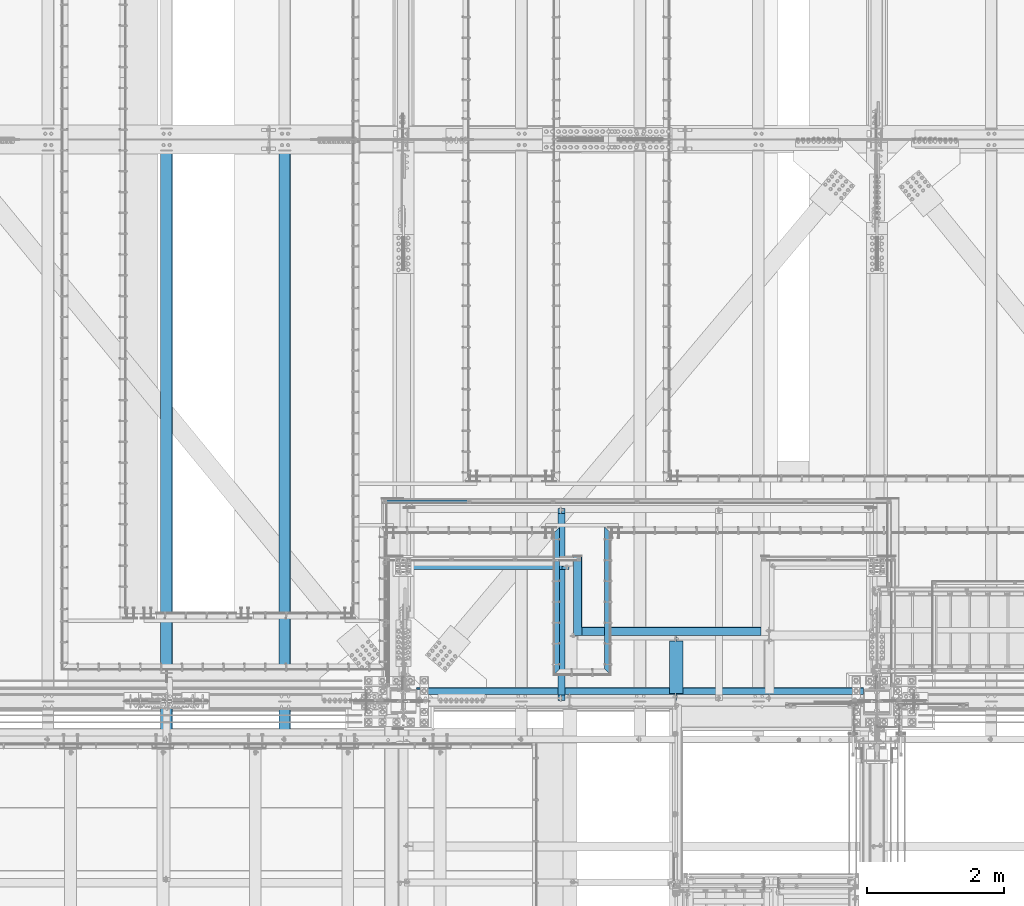
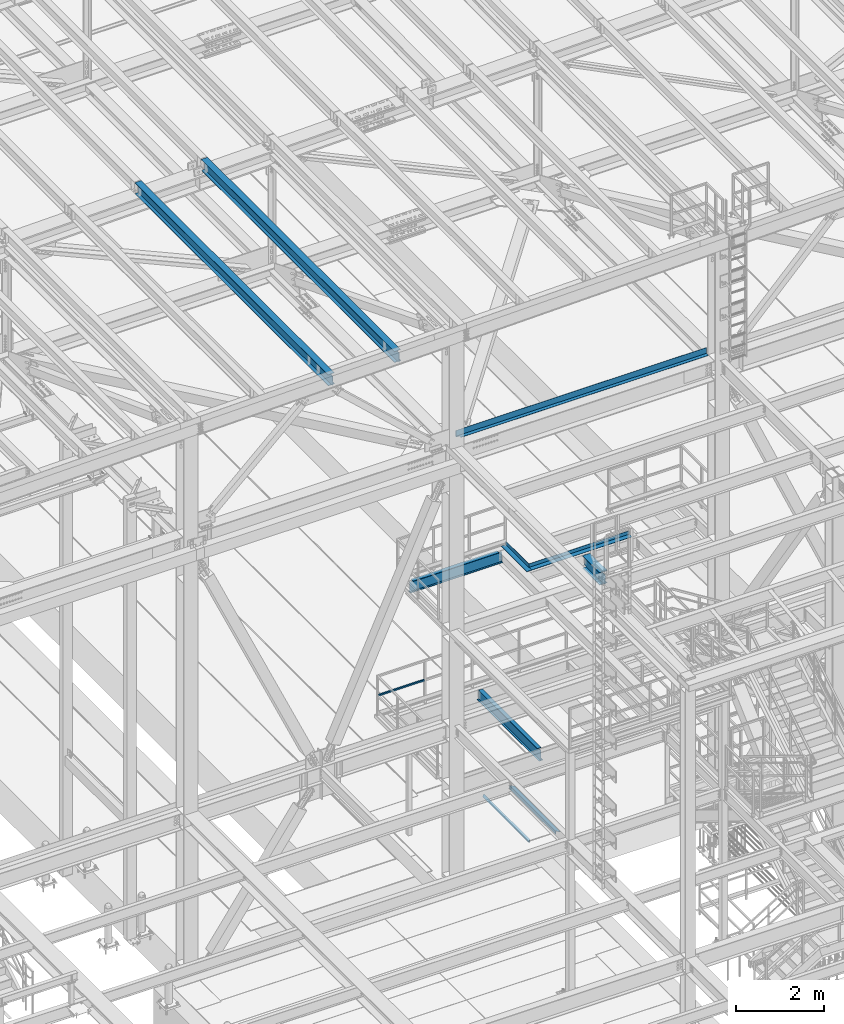
# One storey, part 1782 of 3843: 11 beams, 11 elements without a shape of their own.
"""IFC2X3 building model written with IfcOpenShell, lengths in millimetres."""

from ifc_helpers import new_model, si_unit, frame, origin_with_axes, place, context, subcontext, project, spatial, faceted_brep, material, type_object, element, aggregate, save


model = new_model("IFC2X3")

# Units and contexts
model_context = context("Model", 3, precision=1e-05, world=origin_with_axes())
body_context = subcontext(model_context, "Body", "Model", "MODEL_VIEW")
ifc_project = project(units=[si_unit("LENGTHUNIT", "METRE", prefix="MILLI"), si_unit("AREAUNIT", "SQUARE_METRE"), si_unit("VOLUMEUNIT", "CUBIC_METRE"), si_unit("MASSUNIT", "GRAM", prefix="KILO"), si_unit("TIMEUNIT", "SECOND"), si_unit("PLANEANGLEUNIT", "RADIAN"), si_unit("SOLIDANGLEUNIT", "STERADIAN"), si_unit("THERMODYNAMICTEMPERATUREUNIT", "DEGREE_CELSIUS"), si_unit("LUMINOUSINTENSITYUNIT", "LUMEN")], contexts=[model_context])

# Site, building, storey
site_placement = place(None, origin_with_axes())
site = spatial("IfcSite", under=ifc_project, at=site_placement, CompositionType="ELEMENT")
building_placement = place(site_placement, origin_with_axes())
building = spatial("IfcBuilding", under=site, at=building_placement, Name="Undefined", CompositionType="ELEMENT")
storey_placement = place(building_placement, origin_with_axes())
storey = spatial("IfcBuildingStorey", under=building, at=storey_placement, Name="Undefined", CompositionType="ELEMENT", Elevation=0.0)

# Assembly, beam
assembly_1_placement = place(storey_placement, origin_with_axes())
assembly_1 = element("IfcElementAssembly", 1, at=assembly_1_placement, inside=storey, Name="EMBED_ANGLE", AssemblyPlace="NOTDEFINED", PredefinedType="RIGID_FRAME")
ifc_material_1 = material(Name="STEEL/A36")
beam_type_1 = type_object("IfcBeamType", Name="L3-1/2X3-1/2X5/16", PredefinedType="NOTDEFINED")
beam_1_placement = place(assembly_1_placement, frame((51238.9119901352, 26000.0749968906, 30410.15), z_axis=(0.0, 0.0, -1.0), x_axis=(0.0, 1.0, 0.0)))
beam_1 = element("IfcBeam", 2, at=beam_1_placement, type_object=beam_type_1, material=ifc_material_1, Name="EMBED_ANGLE", ObjectType="L3-1/2X3-1/2X5/16", context=body_context, shape_type="Brep", body=[
    faceted_brep([(88.8999999971129, 44.4500000000007, -44.4499999999971), (88.8999999965163, 44.4499999999971, 44.4500000000007), (2168.52499994361, 44.4499999956824, 44.4500000000007), (2168.52499994361, 44.4499999956824, -44.4500000000007), (80.9624999965163, 36.5124999999971, 44.4500000000007), (2160.58750050484, 36.5124999957043, 44.4500000000007), (80.9624999971129, 36.5125000000007, -36.5124999999971), (2160.58750050484, 36.5124999957043, -36.5125000000007), (3.63797880709171e-12, -44.4499999999971, -36.5125000000007), (2079.62500622933, -44.4500000041371, -36.5125000000007), (3.63797880709171e-12, -44.4499999999971, -44.4500000000007), (2079.62500622933, -44.4500000041371, -44.4500000000007)], [[[0, 1, 2, 3]], [[1, 4, 5, 2]], [[4, 6, 7, 5]], [[6, 8, 9, 7]], [[8, 10, 11, 9]], [[10, 0, 3, 11]], [[5, 7, 9, 11, 3, 2]], [[10, 8, 6, 4, 1, 0]]]),
])
aggregate(assembly_1, [beam_1])

assembly_2_placement = place(storey_placement, origin_with_axes())
assembly_2 = element("IfcElementAssembly", 3, at=assembly_2_placement, inside=storey, Name="EMBED_ANGLE", AssemblyPlace="NOTDEFINED", PredefinedType="RIGID_FRAME")
beam_2_placement = place(assembly_2_placement, frame((51988.2120145524, 26000.0749965095, 30410.15), z_axis=(1.0, 0.0, 0.0), x_axis=(0.0, 1.0, 0.0)))
beam_2 = element("IfcBeam", 4, at=beam_2_placement, type_object=beam_type_1, material=ifc_material_1, Name="EMBED_ANGLE", ObjectType="L3-1/2X3-1/2X5/16", context=body_context, shape_type="Brep", body=[
    faceted_brep([(88.8999999971129, 44.4500000000007, -44.4499999999971), (-3.63797880709171e-12, 44.4499999999971, 44.4500000000007), (2079.62500364689, 44.4500000000007, 44.4500000037006), (2168.52499994361, 44.4499999956824, -44.4500000000007), (-3.63797880709171e-12, 36.5124999999971, 44.4500000000007), (2079.62500364689, 36.5125000000007, 44.4500000037006), (80.9624999971129, 36.5125000000007, -36.5124999999971), (2160.58750050484, 36.5124999957043, -36.5125000000007), (80.9624999971129, -44.4500000000007, -36.5124999999971), (2160.58750334254, -44.4500000000007, -36.5124999961554), (88.8999999971129, -44.4500000000007, -44.4499999999971), (2168.5250033127, -44.4500000000007, -44.4499999961481)], [[[0, 1, 2, 3]], [[1, 4, 5, 2]], [[4, 6, 7, 5]], [[6, 8, 9, 7]], [[8, 10, 11, 9]], [[10, 0, 3, 11]], [[5, 7, 9, 11, 3, 2]], [[10, 8, 6, 4, 1, 0]]]),
])
aggregate(assembly_2, [beam_2])

assembly_3_placement = place(storey_placement, origin_with_axes())
assembly_3 = element("IfcElementAssembly", 5, at=assembly_3_placement, inside=storey, Name="RAIL", AssemblyPlace="NOTDEFINED", PredefinedType="RIGID_FRAME")
ifc_material_2 = material()
beam_type_2 = type_object("IfcBeamType", Name="HSS1-1/2X1-1/2X1/4", PredefinedType="NOTDEFINED")
beam_3_placement = place(assembly_3_placement, frame((49954.3916666376, 28543.2499999997, 33832.8000002631), z_axis=(0.0, 0.0, 1.0), x_axis=(-1.0, 0.0, 0.0)))
beam_3 = element("IfcBeam", 6, at=beam_3_placement, type_object=beam_type_2, material=ifc_material_2, Name="RAIL", ObjectType="HSS1-1/2X1-1/2X1/4", context=body_context, shape_type="Brep", body=[
    faceted_brep([(1211.79166666124, -19.0499999996136, 19.0499992350015), (1211.79166666124, -19.0499992350015, -19.0499992350015), (1211.79166666124, 19.0499992350015, -19.0499992350015), (1211.79166666124, 19.0499992350015, 19.0499992350015), (1211.79166666124, -12.6999993300014, 12.6999993299978), (1211.79166666124, 12.6999993300014, 12.6999993299978), (1211.79166666124, 12.6999993300014, -12.6999993299978), (1211.79166666124, -12.6999993300014, -12.6999993299978), (19.0499992350015, 19.0499992350015, -19.0499992350015), (19.0499992350015, 19.0499992350015, 19.0499992350015), (19.0499992350015, -19.0499992350015, 19.0499992350015), (19.0499992350015, -19.0499992350015, -19.0499992350015), (19.0499992350015, 12.6999993299978, 12.6999993299978), (19.0499992350015, -12.6999993299978, 12.6999993299978), (19.0499992350015, -12.6999993299978, -12.6999993299978), (19.0499992350015, 12.6999993299978, -12.6999993299978)], [[[0, 1, 2, 3], [4, 5, 6, 7]], [[8, 9, 3, 2]], [[9, 10, 0, 3]], [[10, 11, 1, 0]], [[11, 8, 2, 1]], [[11, 10, 9, 8], [12, 13, 14, 15]], [[14, 13, 4, 7]], [[15, 14, 7, 6]], [[12, 15, 6, 5]], [[13, 12, 5, 4]]]),
])
aggregate(assembly_3, [beam_3])

assembly_4_placement = place(storey_placement, origin_with_axes())
assembly_4 = element("IfcElementAssembly", 7, at=assembly_4_placement, inside=storey, Name="BEAM", AssemblyPlace="NOTDEFINED", PredefinedType="RIGID_FRAME")
ifc_material_3 = material(Name="STEEL/A992")
beam_type_3 = type_object("IfcBeamType", Name="W12X26", PredefinedType="NOTDEFINED")
beam_4_placement = place(assembly_4_placement, frame((47259.7592622722, 25006.2092660761, 45800.0192845088), z_axis=(-0.0211520976065004, -0.000583216000144604, 0.999776099247198), x_axis=(0.0, 0.999999829853124, 0.000583346999914719)))
beam_4 = element("IfcBeam", 8, at=beam_4_placement, type_object=beam_type_3, material=ifc_material_3, Name="BEAM", ObjectType="W12X26", context=body_context, shape_type="Brep", body=[
    faceted_brep([(20.6523564862873, -3.17500000041764, -130.17499999042), (20.6522781335407, 3.17499999956635, -130.174999990442), (77.7864852121929, 3.17499999956635, -130.17499999101), (77.7864852121966, -3.17500000042492, -130.174999991017), (82.6465647302175, 3.17499999955908, -131.141729913608), (82.6465647302211, -3.17500000041764, -131.141729913616), (86.7667411983493, 3.1749999995518, -133.894743814111), (86.766741198353, -3.17500000043219, -133.894743814126), (89.5197550988123, 3.17499999954453, -138.014920282309), (89.5197550988159, -3.17500000044674, -138.014920282316), (90.4864850213926, -3.1750000004613, -142.874999800399), (90.4864850213926, 3.1749999995227, -142.874999800384), (90.4864850213635, 3.17499999951542, -146.050000000505), (90.4864850213598, 82.5499999993845, -146.050000000549), (90.4864850213526, 82.5499999993554, -155.575000000572), (90.4864850213562, -82.550000000374, -155.575000000463), (90.4864850213671, -82.5500000003376, -146.050000000432), (90.4864850213635, -3.17500000046857, -146.050000000498), (8826.67843308452, -82.5499999991516, 146.049999988929), (8826.6839882225, -82.5499999991298, 155.574999988945), (90.4864850216909, -82.5499999993917, 155.530575280158), (90.4864850216763, -82.549999999399, 146.050000000316), (8826.6819510511, 82.5500000005995, 155.574999988843), (90.4864850216836, 82.5500000003522, 155.57500000023), (8826.67639591312, 82.5500000005632, 146.049999988812), (90.4864850216727, 82.5500000003231, 146.050000000199), (8826.67737532244, 3.1750000007014, 146.049999988871), (90.4864850216763, 3.17500000045402, 146.050000000258), (77.7864852124731, -3.17499999958818, 130.175000011004), (77.7864852124731, 3.17500000040309, 130.175000011019), (20.8041185718212, 3.17500000040309, 130.175000011543), (20.8041969245642, -3.17499999958818, 130.175000011564), (82.6465647305049, -3.1749999995809, 131.141729933588), (82.6465647304976, 3.17500000041036, 131.141729933603), (86.7667411986404, -3.17499999957363, 133.894743834084), (86.7667411986404, 3.17500000041036, 133.894743834091), (89.5197550991106, -3.17499999955908, 138.014920302267), (89.5197550991106, 3.17500000042492, 138.014920302281), (90.4864850217018, -3.1749999995518, 142.874999820349), (90.4864850216982, 3.17500000044674, 142.874999820364), (90.4864850216727, -3.17499999952997, 146.050000000258), (8826.67745367518, -3.17499999928987, 146.049999988871), (8826.50701775755, 3.1749999997628, -146.050000011892), (8826.50709611029, -3.17500000022847, -146.050000011877), (8826.50807551962, -82.5500000000902, -146.050000011826), (8826.50252038163, -82.5500000001266, -155.57500001185), (8826.50048321023, 82.5499999995955, -155.575000011966), (8826.50603834823, 82.5499999996318, -146.050000011935), (20.662232794919, 3.17499999961728, -113.106450145577), (20.7967225168759, 3.17500000036671, 117.493510640859)], [[[0, 1, 2, 3]], [[3, 2, 4, 5]], [[5, 4, 6, 7]], [[7, 6, 8, 9]], [[10, 11, 12, 13, 14, 15, 16, 17]], [[9, 8, 11, 10]], [[18, 19, 20, 21]], [[19, 22, 23, 20]], [[22, 24, 25, 23]], [[24, 26, 27, 25]], [[28, 29, 30, 31]], [[32, 33, 29, 28]], [[34, 35, 33, 32]], [[36, 37, 35, 34]], [[38, 39, 37, 36]], [[20, 23, 25, 27, 39, 38, 40, 21]], [[41, 18, 21, 40]], [[42, 26, 24, 22, 19, 18, 41, 43, 44, 45, 46, 47]], [[44, 43, 17, 16]], [[45, 44, 16, 15]], [[46, 45, 15, 14]], [[47, 46, 14, 13]], [[42, 47, 13, 12]], [[6, 4, 2, 1, 48, 49, 30, 29, 33, 35, 37, 39, 27, 26, 42, 12, 11, 8]], [[31, 30, 49, 48, 1, 0]], [[43, 41, 40, 38, 36, 34, 32, 28, 31, 0, 3, 5, 7, 9, 10, 17]]]),
])
aggregate(assembly_4, [beam_4])

assembly_5_placement = place(storey_placement, origin_with_axes())
assembly_5 = element("IfcElementAssembly", 9, at=assembly_5_placement, inside=storey, Name="BEAM", AssemblyPlace="NOTDEFINED", PredefinedType="RIGID_FRAME")
beam_5_placement = place(assembly_5_placement, frame((45526.2092622731, 25006.2239840522, 45763.34286726), z_axis=(-0.0211520975334279, -0.000488612999983161, 0.999776149959216), x_axis=(0.0, 0.999999880575396, 0.000488721999792312)))
beam_5 = element("IfcBeam", 10, at=beam_5_placement, type_object=beam_type_3, material=ifc_material_3, Name="BEAM", ObjectType="W12X26", context=body_context, shape_type="Brep", body=[
    faceted_brep([(20.6499461623971, -3.17500000027212, -130.174999998242), (20.6498805192896, 3.17499999971915, -130.174999998249), (77.7866494086084, 3.17499999971915, -130.174999998628), (77.786649408612, -3.17500000027212, -130.174999998599), (82.6467289266766, 3.17499999971187, -131.141729921219), (82.6467289266839, -3.17500000027212, -131.14172992119), (86.7669053948521, 3.17499999971187, -133.8947438217), (86.7669053948594, -3.1750000002794, -133.894743821671), (89.5199192953551, 3.1749999997046, -138.014920289839), (89.5199192953623, -3.17500000028667, -138.01492028981), (90.4866492179681, -3.17500000029395, -142.874999807827), (90.4866492179608, 3.17499999969004, -142.874999807864), (90.4866492178517, 3.17499999968277, -146.049999999792), (90.4866492178517, 82.5499999995518, -146.050000000068), (90.4866492178298, 82.54999999953, -155.575000000041), (90.4866492178371, -82.5500000001775, -155.574999999466), (90.4866492178553, -82.5500000001557, -146.049999999486), (90.4866492178553, -3.17500000030122, -146.04999999977), (8826.64928531732, -82.5499999992826, 146.049999987736), (8826.65393935341, -82.5499999992535, 155.574999987708), (90.4866492165784, -82.54999999953, 155.537788344329), (90.4866492165929, -82.5499999995372, 146.049999999821), (8826.65223263258, 82.550000000454, 155.574999987133), (90.4866492165711, 82.5500000001994, 155.574999999219), (8826.6475785965, 82.5500000004322, 146.049999987161), (90.4866492165856, 82.5500000001775, 146.049999999253), (8826.64839913535, 3.17500000057771, 146.049999987437), (90.4866492165893, 3.17500000032305, 146.049999999523), (77.7866494076043, -3.17499999969732, 130.174999999312), (77.786649407597, 3.1750000002794, 130.174999999283), (20.7770908392231, 3.1750000002794, 130.174999998919), (20.7771564823342, -3.17499999971187, 130.174999998941), (82.6467289256616, -3.1749999997046, 131.141729921881), (82.6467289256543, 3.17500000028667, 131.141729921845), (86.766905393808, -3.17499999969732, 133.89474382234), (86.7669053938043, 3.17500000029395, 133.894743822304), (89.5199192942746, -3.17499999969004, 138.014920290458), (89.5199192942673, 3.17500000030122, 138.014920290429), (90.486649216833, -3.17499999968277, 142.874999808468), (90.4866492168258, 3.17500000031578, 142.874999808446), (90.4866492165893, -3.17499999967549, 146.049999999545), (8826.64846477846, -3.17499999941356, 146.049999987459), (8826.50567536176, 3.17499999993743, -146.050000011885), (8826.50574100488, -3.17500000004657, -146.050000011863), (8826.50656154374, -82.549999999901, -146.050000011579), (8826.50190750765, -82.5499999999229, -155.575000011559), (8826.50020078681, 82.5499999997846, -155.575000012126), (8826.50485482291, 82.5499999997992, -146.050000012161), (20.6582189573455, 3.17499999975553, -113.109463582012), (20.7708930356057, 3.17500000025757, 117.490508894887)], [[[0, 1, 2, 3]], [[3, 2, 4, 5]], [[5, 4, 6, 7]], [[7, 6, 8, 9]], [[10, 11, 12, 13, 14, 15, 16, 17]], [[9, 8, 11, 10]], [[18, 19, 20, 21]], [[19, 22, 23, 20]], [[22, 24, 25, 23]], [[24, 26, 27, 25]], [[28, 29, 30, 31]], [[32, 33, 29, 28]], [[34, 35, 33, 32]], [[36, 37, 35, 34]], [[38, 39, 37, 36]], [[20, 23, 25, 27, 39, 38, 40, 21]], [[41, 18, 21, 40]], [[42, 26, 24, 22, 19, 18, 41, 43, 44, 45, 46, 47]], [[44, 43, 17, 16]], [[45, 44, 16, 15]], [[46, 45, 15, 14]], [[47, 46, 14, 13]], [[42, 47, 13, 12]], [[6, 4, 2, 1, 48, 49, 30, 29, 33, 35, 37, 39, 27, 26, 42, 12, 11, 8]], [[31, 30, 49, 48, 1, 0]], [[43, 41, 40, 38, 36, 34, 32, 28, 31, 0, 3, 5, 7, 9, 10, 17]]]),
])
aggregate(assembly_5, [beam_5])

assembly_6_placement = place(storey_placement, origin_with_axes())
assembly_6 = element("IfcElementAssembly", 11, at=assembly_6_placement, inside=storey, Name="BEAM", AssemblyPlace="NOTDEFINED", PredefinedType="RIGID_FRAME")
beam_type_4 = type_object("IfcBeamType", Name="W12X19", PredefinedType="NOTDEFINED")
beam_6_placement = place(assembly_6_placement, frame((48996.6, 27597.1, 37311.0125), z_axis=(0.0, 0.0, 1.0), x_axis=(1.0, 0.0, 0.0)))
beam_6 = element("IfcBeam", 12, at=beam_6_placement, type_object=beam_type_4, material=ifc_material_3, Name="BEAM", ObjectType="W12X19", context=body_context, shape_type="Brep", body=[
    faceted_brep([(66.6750001907276, -3.17500000000291, 128.587500000001), (66.6750001907276, 3.17500000000291, 128.587500000001), (15.8750000000146, 3.17500000000291, 128.587500001042), (15.8750000000146, -3.17500000000291, 128.587500001042), (71.535079708774, -3.17500000000291, 129.554229922593), (71.535079708774, 3.17500000000291, 129.554229922593), (75.6552561769277, -3.17500000000291, 132.307243823067), (75.6552561769277, 3.17500000000291, 132.307243823067), (78.4082700774052, -3.17500000000291, 136.42742029122), (78.4082700774052, 3.17500000000291, 136.42742029122), (79.3749999999927, -3.17500000000291, 141.287499809267), (79.3749999999927, 3.17500000000291, 141.287499809267), (79.375, -50.7999999999993, 153.890648237968), (79.3749999999927, 50.8000000000029, 153.987500000003), (79.3749999999927, 50.8000000000029, 144.462500000001), (79.3749999999927, 3.17500000000291, 144.462500000001), (79.3749999999927, -3.17500000000291, 144.462500000001), (79.3749999999927, -50.8000000000029, 144.462500000001), (15.8749999999927, -3.17500000000291, -144.462500000001), (15.8749999999927, -50.8000000000029, -144.462500000001), (2421.73125, -50.7999999999993, -144.462500000001), (2421.73125, -3.17499999999927, -144.462500000001), (15.8749999999927, -50.8000000000029, -153.987500000003), (2421.73125, -50.7999999999993, -153.987500000003), (15.8749999999927, 50.8000000000029, -153.987500000003), (2421.73125, 50.7999999999993, -153.987500000003), (15.8749999999927, 50.8000000000029, -144.462500000001), (2421.73125, 50.7999999999993, -144.462500000001), (15.8749999999927, 3.17500000000291, -144.462500000001), (2421.73125, 3.17499999999927, -144.462500000001), (2421.73125, -3.17499999999927, 115.887499999997), (2421.73125, -3.17499999999927, -114.712500000001), (2421.73125, 3.17499999999927, 128.587500000001), (2421.73125, -3.17499999999927, 128.587500000001), (2332.83124980928, 3.17499999999927, 128.587500000001), (2332.83124980928, -3.17499999999927, 128.587500000001), (2327.97117029123, 3.17499999999927, 129.554229922593), (2327.97117029123, -3.17499999999927, 129.554229922593), (2323.85099382308, 3.17499999999927, 132.307243823067), (2323.85099382308, -3.17499999999927, 132.307243823067), (2321.0979799226, 3.17499999999927, 136.42742029122), (2321.0979799226, -3.17499999999927, 136.42742029122), (2320.13125000001, 3.17499999999927, 141.287499809267), (2320.13125000001, -3.17499999999927, 141.287499809267), (2320.13125000001, -50.7999999999993, 153.987500000003), (2320.13125000001, -50.7999999999993, 144.462500000001), (2320.13125000001, -3.17499999999927, 144.462500000001), (2320.13125000001, 3.17499999999927, 144.462500000001), (2320.13125000001, 50.7999999999993, 144.462500000001), (2320.13125000001, 50.7999999999993, 153.987500000003), (15.8750000000073, -3.17499999999927, 115.887499999997), (15.8750000000073, -3.17499999999927, -114.712500000001)], [[[0, 1, 2, 3]], [[4, 5, 1, 0]], [[6, 7, 5, 4]], [[8, 9, 7, 6]], [[10, 11, 9, 8]], [[12, 13, 14, 15, 11, 10, 16, 17]], [[18, 19, 20, 21]], [[19, 22, 23, 20]], [[22, 24, 25, 23]], [[24, 26, 27, 25]], [[26, 28, 29, 27]], [[30, 31, 21, 20, 23, 25, 27, 29, 32, 33]], [[33, 32, 34, 35]], [[35, 34, 36, 37]], [[37, 36, 38, 39]], [[39, 38, 40, 41]], [[41, 40, 42, 43]], [[44, 45, 46, 43, 42, 47, 48, 49]], [[45, 44, 12, 17]], [[46, 45, 17, 16]], [[8, 6, 4, 0, 3, 50, 51, 18, 21, 31, 30, 33, 35, 37, 39, 41, 43, 46, 16, 10]], [[28, 26, 24, 22, 19, 18, 51, 50, 3, 2]], [[47, 42, 40, 38, 36, 34, 32, 29, 28, 2, 1, 5, 7, 9, 11, 15]], [[48, 47, 15, 14]], [[49, 48, 14, 13]], [[44, 49, 13, 12]]]),
])
aggregate(assembly_6, [beam_6])

assembly_7_placement = place(storey_placement, origin_with_axes())
assembly_7 = element("IfcElementAssembly", 13, at=assembly_7_placement, inside=storey, Name="BEAM", AssemblyPlace="NOTDEFINED", PredefinedType="RIGID_FRAME")
beam_7_placement = place(assembly_7_placement, frame((51308.0, 25615.8999999464, 33043.8124999995), z_axis=(0.0, 0.0, 1.0), x_axis=(0.0, 1.0, 0.0)))
beam_7 = element("IfcBeam", 14, at=beam_7_placement, type_object=beam_type_4, material=ifc_material_3, Name="BEAM", ObjectType="W12X19", context=body_context, shape_type="Brep", body=[
    faceted_brep([(2751.93125005356, -50.8000000000029, 153.987500000003), (2751.93125005356, -50.8000000000029, 144.462500000001), (2751.93125005356, -3.17500000000291, 144.462500000001), (2751.93125005356, -3.17500000000291, 141.287499809274), (2751.93125005356, 3.17500000000291, 141.287499809274), (2751.93125005356, 3.17500000000291, 144.462500000001), (2751.93125005356, 50.8000000000029, 144.462500000001), (2751.93125005356, 50.8000000000029, 153.987500000003), (2752.89797997615, -3.17500000000291, 136.427420291227), (2752.89797997615, 3.17500000000291, 136.427420291227), (2755.65099387663, -3.17500000000291, 132.307243823074), (2755.65099387663, 3.17500000000291, 132.307243823074), (2759.77117034478, -3.17500000000291, 129.5542299226), (2759.77117034478, 3.17500000000291, 129.5542299226), (2764.63124986283, -3.17500000000291, 128.587500000009), (2764.63124986283, 3.17500000000291, 128.587500000009), (2828.13125005356, -3.17500000000291, 128.587500000009), (2828.13125005356, 3.17500000000291, 128.587500000009), (92.8687499999796, -50.8000000000002, 153.987499810319), (92.8687499999796, 50.8000000000002, 153.987500000003), (92.8687499999796, 50.8000000000002, 144.462500000001), (92.8687499999796, 3.17500000000018, 144.462500000001), (92.8687499999796, 3.17500000000018, 141.287499809259), (92.8687499999796, -3.17500000000018, 141.287499809259), (92.8687499999796, -3.17500000000018, 144.462500000001), (92.8687499999796, -50.8000000000002, 144.462500000001), (91.9020200773957, 3.17500000000018, 136.427420291213), (91.9020200773957, -3.17500000000018, 136.427420291213), (89.1490061769146, 3.17500000000018, 132.307243823059), (89.1490061769146, -3.17500000000018, 132.307243823059), (85.0288297087536, 3.17500000000018, 129.554229922585), (85.0288297087536, -3.17500000000018, 129.554229922585), (80.1687501907145, 3.17500000000018, 128.587499999994), (80.1687501907145, -3.17500000000018, 128.587499999994), (16.6687499999971, 3.17499999999927, 128.587500000001), (16.6687499999971, -3.17499999999927, 128.587500000001), (16.6687499999971, 3.17499999999927, 115.887499999742), (16.6687499999971, 3.17499999999927, -114.712500000256), (16.6687499999971, 3.17499999999927, -144.462500000001), (16.6687499999971, 50.7999999999993, -144.462500000001), (16.6687499999971, 50.7999999999993, -153.987500000003), (16.6687499999971, -50.7999999999993, -153.987500000003), (16.6687499999971, -50.7999999999993, -144.462500000001), (16.6687499999971, -3.17499999999927, -144.462500000001), (2828.13125005356, 3.17500000000291, -144.462500000001), (2828.13125005356, 50.8000000000029, -144.462500000001), (2828.13125005356, 50.8000000000029, -153.987500000003), (2828.13125005356, -50.8000000000029, -153.987500000003), (2828.13125005356, -50.8000000000029, -144.462500000001), (2828.13125005356, -3.17500000000291, -144.462500000001), (2828.13125005356, 3.17500000000291, 115.887499999997), (2828.13125005356, 3.17500000000291, -114.712500000001)], [[[0, 1, 2, 3, 4, 5, 6, 7]], [[8, 9, 4, 3]], [[10, 11, 9, 8]], [[12, 13, 11, 10]], [[14, 15, 13, 12]], [[16, 17, 15, 14]], [[18, 19, 20, 21, 22, 23, 24, 25]], [[23, 22, 26, 27]], [[27, 26, 28, 29]], [[29, 28, 30, 31]], [[31, 30, 32, 33]], [[33, 32, 34, 35]], [[36, 37, 38, 39, 40, 41, 42, 43, 35, 34]], [[39, 38, 44, 45]], [[40, 39, 45, 46]], [[41, 40, 46, 47]], [[42, 41, 47, 48]], [[43, 42, 48, 49]], [[12, 10, 8, 3, 2, 24, 23, 27, 29, 31, 33, 35, 43, 49, 16, 14]], [[25, 24, 2, 1]], [[18, 25, 1, 0]], [[19, 18, 0, 7]], [[20, 19, 7, 6]], [[21, 20, 6, 5]], [[50, 51, 44, 38, 37, 36, 34, 32, 30, 28, 26, 22, 21, 5, 4, 9, 11, 13, 15, 17]], [[49, 48, 47, 46, 45, 44, 51, 50, 17, 16]]]),
])
aggregate(assembly_7, [beam_7])

assembly_8_placement = place(storey_placement, origin_with_axes())
assembly_8 = element("IfcElementAssembly", 15, at=assembly_8_placement, inside=storey, Name="BENT_PLATE", AssemblyPlace="NOTDEFINED", PredefinedType="RIGID_FRAME")
beam_type_5 = type_object("IfcBeamType", PredefinedType="NOTDEFINED")
beam_8_placement = place(assembly_8_placement, frame((52461.3185, 25720.675, 42471.975), z_axis=(-1.0, 0.0, 0.0), x_axis=(0.0, 1.0, 0.0)))
beam_8 = element("IfcBeam", 16, at=beam_8_placement, type_object=beam_type_5, material=ifc_material_1, Name="BENT_PLATE", context=body_context, shape_type="Brep", body=[
    faceted_brep([(66.6749999999956, -3.17500000000291, 3194.8435), (66.6749999999956, 3.17500000000291, 3194.8435), (0.0, 3.17500000000291, 3194.8435), (0.0, -3.17500000000291, 3194.8435), (66.6749999999956, -3.17500000000291, 3271.04349999999), (66.6749999999956, 3.17500000000291, 3271.0435), (92.0750000000044, -3.17500000000291, -3271.0435), (0.0, -3.17500000000291, -3271.0435), (0.0, 3.17500000000291, -3271.0435), (98.4250000000029, 3.17500000000291, -3271.0435), (98.4250000000029, -161.925000000003, -3271.0435), (92.0750000000044, -161.925000000003, -3271.0435), (98.4250000000029, 3.17500000000291, 3271.0435), (98.4250000000029, -161.925000000003, 3271.0435), (92.0750000000044, -161.925000000003, 3271.0435), (92.0750000000044, -3.17500000000291, 3271.0435)], [[[0, 1, 2, 3]], [[4, 5, 1, 0]], [[6, 7, 8, 9, 10, 11]], [[9, 12, 13, 10]], [[14, 11, 10, 13]], [[15, 6, 11, 14]], [[3, 7, 6, 15, 4, 0]], [[8, 7, 3, 2]], [[12, 9, 8, 2, 1, 5]], [[15, 14, 13, 12, 5, 4]]]),
])
aggregate(assembly_8, [beam_8])

assembly_9_placement = place(storey_placement, origin_with_axes())
assembly_9 = element("IfcElementAssembly", 17, at=assembly_9_placement, inside=storey, Name="BEAM", AssemblyPlace="NOTDEFINED", PredefinedType="RIGID_FRAME")
beam_type_6 = type_object("IfcBeamType", PredefinedType="NOTDEFINED")
beam_9_placement = place(assembly_9_placement, frame((51485.8, 27163.31475, 37468.175), z_axis=(0.0, -1.0, 0.0), x_axis=(1.0, 0.0, 0.0)))
beam_9 = element("IfcBeam", 18, at=beam_9_placement, type_object=beam_type_6, material=ifc_material_1, Name="BENT_PLATE", context=body_context, shape_type="Brep", body=[
    faceted_brep([(127.000003051748, 98.4249984741255, 461.56475001165), (120.650003051742, 98.4249984741255, 461.564750170401), (120.650003051742, 3.17500000000291, 461.564750170393), (127.000003051748, 3.17499999999563, 461.564750011643), (127.000003051748, 3.17500000001019, 583.009000011643), (120.650003051742, 3.17500000000291, 583.008999999998), (0.0, 3.17500000000291, -583.008999999998), (0.0, -3.17500000000291, -583.008999999998), (0.0, -3.17500000000291, 583.008999999998), (0.0, 3.17500000000291, 583.008999999998), (0.0, 3.17500000000291, 461.564753186667), (127.000003051748, -3.17500000000291, -583.008999999998), (120.650003051742, 3.17500000000291, -583.008999999998), (120.650003051742, 98.4249984741255, -583.008999999998), (127.000003051748, 98.4249984741255, -583.008999999998), (127.000003051748, -3.17500000000291, 583.008999999998)], [[[0, 1, 2, 3]], [[4, 3, 2, 5]], [[6, 7, 8, 9, 10]], [[11, 7, 6, 12, 13, 14]], [[8, 7, 11, 15]], [[9, 8, 15, 4, 5]], [[6, 10, 9, 5, 2, 12]], [[13, 12, 2, 1]], [[14, 13, 1, 0]], [[15, 11, 14, 0, 3, 4]]]),
])
aggregate(assembly_9, [beam_9])

assembly_10_placement = place(storey_placement, origin_with_axes())
assembly_10 = element("IfcElementAssembly", 19, at=assembly_10_placement, inside=storey, Name="BEAM", AssemblyPlace="NOTDEFINED", PredefinedType="RIGID_FRAME")
beam_10_placement = place(assembly_10_placement, frame((52920.9, 26581.1, 37468.175), z_axis=(-1.0, 0.0, 0.0), x_axis=(0.0, 1.0, 0.0)))
beam_10 = element("IfcBeam", 20, at=beam_10_placement, type_object=beam_type_6, material=ifc_material_1, Name="BENT_PLATE", context=body_context, shape_type="Brep", body=[
    faceted_brep([(0.0, -3.17500000000291, -1308.1), (0.0, -3.17500000000291, 1308.1), (0.0, 3.17500000000291, 1308.1), (0.0, 3.17500000000291, -1308.1), (126.999999999996, 3.17500000000291, 1308.1), (126.999999999996, 3.17500000000291, -1308.1), (120.649999999998, -3.17500000000291, -1308.1), (120.649999999998, -3.17500000000291, 1308.1), (126.999999999996, -98.4249984741182, 1308.1), (126.999999999996, -98.4249984741182, -1308.1), (120.649999999998, -98.4249984741182, 1308.1), (120.649999999998, -98.4249984741182, -1308.1)], [[[0, 1, 2, 3]], [[3, 2, 4, 5]], [[1, 0, 6, 7]], [[5, 4, 8, 9]], [[4, 2, 1, 7, 10, 8]], [[7, 6, 11, 10]], [[6, 0, 3, 5, 9, 11]], [[10, 11, 9, 8]]]),
])
aggregate(assembly_10, [beam_10])

assembly_11_placement = place(storey_placement, origin_with_axes())
assembly_11 = element("IfcElementAssembly", 21, at=assembly_11_placement, inside=storey, Name="BEAM", AssemblyPlace="NOTDEFINED", PredefinedType="RIGID_FRAME")
beam_type_7 = type_object("IfcBeamType", Name="W14X43", PredefinedType="NOTDEFINED")
beam_11_placement = place(assembly_11_placement, frame((52990.75, 25615.9, 37291.9625), z_axis=(0.0, 0.0, 1.0), x_axis=(0.0, 1.0, 0.0)))
beam_11 = element("IfcBeam", 22, at=beam_11_placement, type_object=beam_type_7, material=ifc_material_3, Name="BEAM", ObjectType="W14X43", context=body_context, shape_type="Brep", body=[
    faceted_brep([(123.031750000006, -3.96875, 159.940499999997), (123.031750000006, 3.96875, 159.940499999997), (150.805846741696, 3.96875, 150.284265447786), (150.805846741696, -3.96875, 150.284265447786), (155.115364045432, 3.96875, 147.238154167171), (155.115364045432, -3.96875, 147.238154167171), (157.141757621015, 3.96875, 142.365325173465), (157.141757621015, -3.96875, 142.365325173465), (156.262970011077, 3.96875, 137.161627866575), (156.262970011077, -3.96875, 137.161627866575), (152.748769336082, 3.96875, 133.224480810524), (152.748769336082, -3.96875, 133.224480810524), (147.67793652137, 3.96875, 131.762499999997), (147.67793652137, -3.96875, 131.762499999997), (16.668750000008, 3.96875, 131.762499999997), (16.668750000008, -3.96875, 131.762499999997), (16.668750000008, 3.96875, -131.762499999997), (16.668750000008, -3.96875, -131.762499999997), (149.118936521369, 3.96875, -131.762499999997), (149.118936521369, -3.96875, -131.762499999997), (154.189769336084, 3.96875, -133.224480810524), (154.189769336084, -3.96875, -133.224480810524), (157.70397001108, 3.96875, -137.161627866575), (157.70397001108, -3.96875, -137.161627866575), (158.582757621018, 3.96875, -142.365325173465), (158.582757621018, -3.96875, -142.365325173465), (156.556364045435, 3.96875, -147.238154167171), (156.556364045435, -3.96875, -147.238154167171), (152.246846741695, 3.96875, -150.284265447786), (152.246846741695, -3.96875, -150.284265447786), (124.472750000008, 3.96875, -159.940499999997), (124.472750000008, -3.96875, -159.940499999997), (117.893546962492, 3.96875, -159.940499999997), (117.893546962492, -3.96875, -159.940499999997), (885.825000000004, 101.599999999999, -160.337500000001), (885.825000000004, 101.599999999999, -173.037499999999), (110.332156075034, 101.599999999999, -173.037499999999), (117.664343924978, 101.599999999999, -160.337500000001), (885.825000000004, -101.599999999999, -173.037499999999), (110.332156075034, -101.599999999999, -173.037499999999), (885.825000000004, -101.599999999999, -160.337500000001), (117.664343924978, -101.599999999999, -160.337500000001), (885.825000000004, -3.96875, -160.337500000001), (117.664343924978, -3.96875, -160.337500000001), (117.664343924978, 3.96875, -160.337500000001), (885.825000000004, 3.96875, -160.337500000001), (886.791729922592, 3.96875, -155.477420291223), (886.791729922592, -3.96875, -155.477420291223), (889.544743823069, 3.96875, -151.357243823069), (889.544743823069, -3.96875, -151.357243823069), (893.664920291223, 3.96875, -148.604229922596), (893.664920291223, -3.96875, -148.604229922596), (898.52499980927, 3.96875, -147.637500000004), (898.52499980927, -3.96875, -147.637500000004), (949.325000000008, -3.96875, -147.637500000004), (949.325000000008, 3.96875, -147.637500000004), (949.325000000008, 3.96875, -95.6624999999985), (949.325000000008, 3.96875, 134.9375), (949.325000000008, 3.96875, 147.637499999997), (949.325000000008, -3.96875, 147.637499999997), (898.52499980927, 3.96875, 147.637499999997), (898.52499980927, -3.96875, 147.637499999997), (893.664920291223, 3.96875, 148.604229922588), (893.664920291223, -3.96875, 148.604229922588), (889.544743823069, 3.96875, 151.357243823062), (889.544743823069, -3.96875, 151.357243823062), (886.791729922592, 3.96875, 155.477420291216), (886.791729922592, -3.96875, 155.477420291216), (885.825000000004, -101.599999999999, 173.037499999999), (885.825000000004, -101.599999999999, 160.337500000001), (885.825000000004, -3.96875, 160.337500000001), (885.825000000004, 3.96875, 160.337500000001), (885.825000000004, 101.599999999999, 160.337500000001), (885.825000000004, 101.599999999999, 173.037499999999), (110.3317630852, -3.96875, 160.337500000001), (110.102548455761, -3.96875, 159.940499948083), (110.102548455761, 3.96875, 159.940499948083), (110.3317630852, 3.96875, 160.337500000001), (110.3317630852, 101.599999999999, 160.337500000001), (117.664320801076, 101.599999999999, 173.037499999999), (117.664320801076, -101.599999999999, 173.037499999999), (110.3317630852, -101.599999999999, 160.337500000001)], [[[0, 1, 2, 3]], [[3, 2, 4, 5]], [[5, 4, 6, 7]], [[7, 6, 8, 9]], [[9, 8, 10, 11]], [[11, 10, 12, 13]], [[13, 12, 14, 15]], [[15, 14, 16, 17]], [[18, 19, 17, 16]], [[19, 18, 20, 21]], [[21, 20, 22, 23]], [[23, 22, 24, 25]], [[25, 24, 26, 27]], [[27, 26, 28, 29]], [[29, 28, 30, 31]], [[31, 30, 32, 33]], [[34, 35, 36, 37]], [[35, 38, 39, 36]], [[38, 40, 41, 39]], [[40, 42, 43, 41]], [[33, 32, 44, 37, 36, 39, 41, 43]], [[45, 34, 37, 44]], [[40, 38, 35, 34, 45, 42]], [[42, 45, 46, 47]], [[47, 46, 48, 49]], [[49, 48, 50, 51]], [[51, 50, 52, 53]], [[54, 53, 52, 55]], [[56, 57, 58, 59, 54, 55]], [[59, 58, 60, 61]], [[61, 60, 62, 63]], [[63, 62, 64, 65]], [[65, 64, 66, 67]], [[68, 69, 70, 71, 72, 73]], [[67, 66, 71, 70]], [[0, 3, 5, 7, 9, 11, 13, 15, 17, 19, 21, 23, 25, 27, 29, 31, 33, 43, 42, 47, 49, 51, 53, 54, 59, 61, 63, 65, 67, 70, 74, 75]], [[1, 0, 75, 76]], [[71, 66, 64, 62, 60, 58, 57, 56, 55, 52, 50, 48, 46, 45, 44, 32, 30, 28, 26, 24, 22, 20, 18, 16, 14, 12, 10, 8, 6, 4, 2, 1, 76, 77]], [[72, 71, 77, 78]], [[73, 72, 78, 79]], [[68, 73, 79, 80]], [[69, 68, 80, 81]], [[70, 69, 81, 74]], [[80, 79, 78, 77, 76, 75, 74, 81]]]),
])
aggregate(assembly_11, [beam_11])

save(model, "model.ifc")
